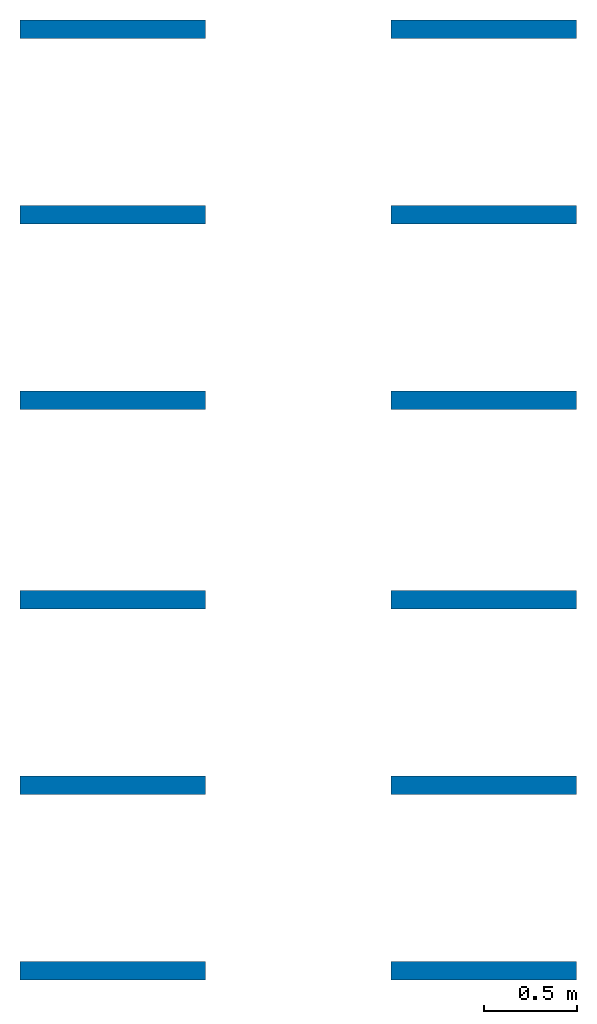
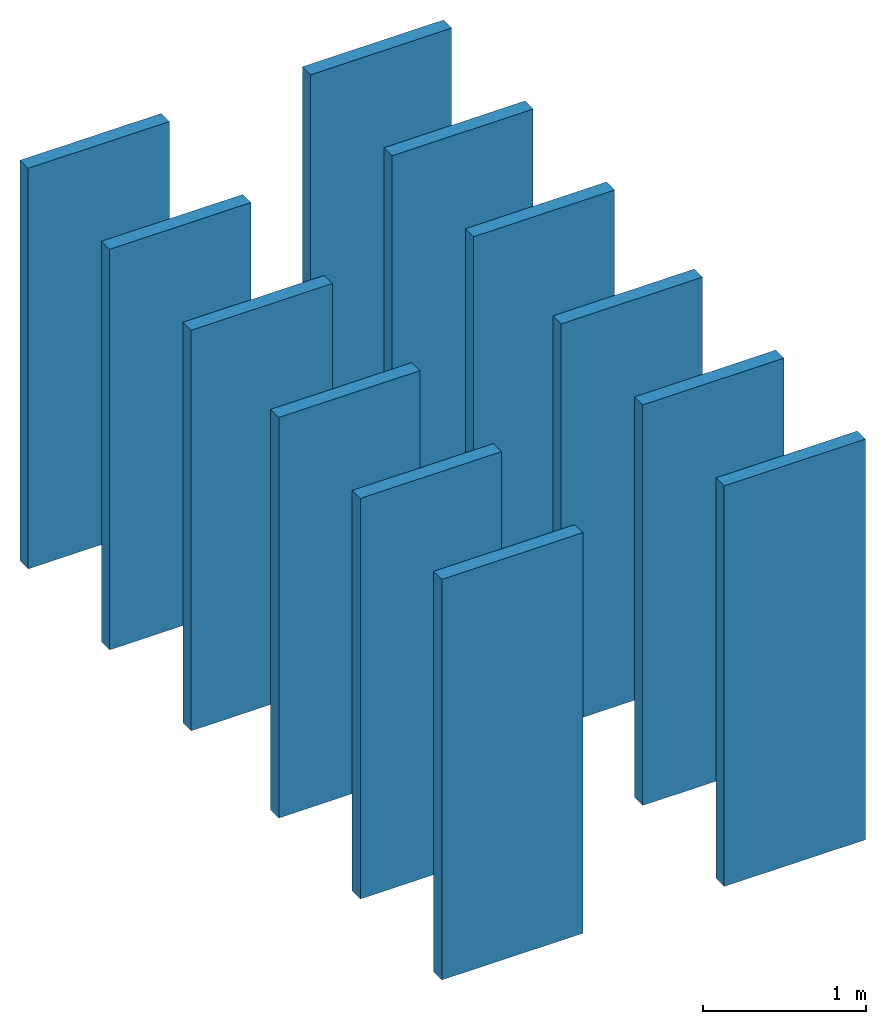
# One storey: 12 walls.
"""IFC4 building model written with IfcOpenShell, lengths in metres."""

import ifcopenshell
import ifcopenshell.guid

model = None  # the IFC model being written
_history = None  # IfcOwnerHistory: only IFC2X3 demands one
_inside = {}  # id of a spatial element -> (the spatial element, [elements in it])
_under = {}  # id of a project, library or spatial element -> (it, [spatial elements below it])
_declared = {}  # id of a project -> (the project, [libraries it declares])
_typed = {}  # id of a type object -> (the type object, [elements of that type])
_made_of = {}  # id of a material, layer set ... -> (it, [elements and type objects made of it])


def new_model(schema):
    """Start an empty IFC model of exactly this schema.

    Asked for "IFC4X3", IfcOpenShell would pick the latest addendum, in which some entities
    have other attributes; the version numbers below select the first issue.
    IFC2X3 requires an IfcOwnerHistory on every rooted entity: one is made here for all.
    """
    global model, _history
    if schema == "IFC4X3":
        model = ifcopenshell.file(schema_version=(4, 3, 0, 0))
    else:
        model = ifcopenshell.file(schema=schema)
    _inside.clear()
    _under.clear()
    _declared.clear()
    _typed.clear()
    _made_of.clear()
    _history = None
    if model.schema == "IFC2X3":
        org = make("IfcOrganization", Name="unknown")
        user = make(
            "IfcPersonAndOrganization",
            ThePerson=make("IfcPerson", FamilyName="unknown"),
            TheOrganization=org,
        )
        app = make(
            "IfcApplication",
            ApplicationDeveloper=org,
            Version="unknown",
            ApplicationFullName="unknown",
            ApplicationIdentifier="unknown",
        )
        _history = make(
            "IfcOwnerHistory",
            OwningUser=user,
            OwningApplication=app,
            ChangeAction="ADDED",
            CreationDate=0,
        )
    return model


def make(cls, **values):
    """One entity of the class cls with the attributes given. An attribute that is None is left unset."""
    return model.create_entity(
        cls, **{name: value for name, value in values.items() if value is not None}
    )


def entity(cls, *values):
    """Any entity or typed value of the class cls, its attributes in the order of the schema. None: left unset."""
    e = model.create_entity(cls)
    for i, value in enumerate(values):
        if value is not None:
            e[i] = value
    return e


def rooted(cls, **values):
    """An entity with a GlobalId (a new one), such as an element, a storey or a relation."""
    return make(cls, GlobalId=ifcopenshell.guid.new(), OwnerHistory=_history, **values)


def si_unit(unit_type, name, prefix=None):
    """IfcSIUnit, for example si_unit("LENGTHUNIT", "METRE", prefix="MILLI")."""
    return make("IfcSIUnit", UnitType=unit_type, Prefix=prefix, Name=name)


def converted_unit(unit_type, name, factor, base, dimensions=None, offset=None):
    """IfcConversionBasedUnit, such as the inch: factor (a typed value) times the base unit."""
    return make(
        "IfcConversionBasedUnit"
        if offset is None
        else "IfcConversionBasedUnitWithOffset",
        ConversionOffset=offset,
        Dimensions=None
        if dimensions is None
        else entity("IfcDimensionalExponents", *dimensions),
        UnitType=unit_type,
        Name=name,
        ConversionFactor=make(
            "IfcMeasureWithUnit", ValueComponent=factor, UnitComponent=base
        ),
    )


def assignment(units):
    """IfcUnitAssignment: the units of a project."""
    return None if units is None else make("IfcUnitAssignment", Units=units)


def point(xyz):
    """IfcCartesianPoint."""
    return None if xyz is None else make("IfcCartesianPoint", Coordinates=xyz)


def direction(xyz):
    """IfcDirection."""
    return None if xyz is None else make("IfcDirection", DirectionRatios=xyz)


def frame(location, z_axis=None, x_axis=None):
    """IfcAxis2Placement3D, a coordinate frame: its origin and axes. An axis left out is left unset."""
    return make(
        "IfcAxis2Placement3D",
        Location=point(location),
        Axis=direction(z_axis),
        RefDirection=direction(x_axis),
    )


def frame_2d(location, x_axis=None):
    """IfcAxis2Placement2D, a coordinate frame in the plane: its origin and x axis."""
    return make(
        "IfcAxis2Placement2D", Location=point(location), RefDirection=direction(x_axis)
    )


def origin_with_axes():
    """The frame at (0, 0, 0) with the z axis (0, 0, 1) and the x axis (1, 0, 0) written out."""
    return frame((0.0, 0.0, 0.0), z_axis=(0.0, 0.0, 1.0), x_axis=(1.0, 0.0, 0.0))


def origin_2d_with_axis():
    """The frame at (0, 0) in the plane with the x axis (1, 0) written out."""
    return frame_2d((0.0, 0.0), x_axis=(1.0, 0.0))


def place(relative_to, where):
    """IfcLocalPlacement: puts the frame where relative to a parent placement (None: the world)."""
    return make(
        "IfcLocalPlacement", PlacementRelTo=relative_to, RelativePlacement=where
    )


def context(
    kind, dimensions, precision=None, world=None, true_north=None, identifier=None
):
    """IfcGeometricRepresentationContext, for example the 3D "Model" context."""
    return make(
        "IfcGeometricRepresentationContext",
        ContextIdentifier=identifier,
        ContextType=kind,
        CoordinateSpaceDimension=dimensions,
        Precision=precision,
        WorldCoordinateSystem=world,
        TrueNorth=true_north,
    )


def subcontext(parent, identifier, kind, view, scale=None):
    """IfcGeometricRepresentationSubContext, for example "Body" below "Model"."""
    return make(
        "IfcGeometricRepresentationSubContext",
        ContextIdentifier=identifier,
        ContextType=kind,
        ParentContext=parent,
        TargetScale=scale,
        TargetView=view,
    )


def project(units=None, contexts=None):
    """IfcProject with its units and contexts."""
    return rooted(
        "IfcProject",
        Name="project",
        RepresentationContexts=contexts,
        UnitsInContext=assignment(units),
    )


def spatial(cls, under=None, at=None, **own):
    """A site, building, storey or space (cls), placed at a placement, below another one or the project."""
    s = rooted(cls, ObjectPlacement=at, **own)
    if under is not None:
        _under.setdefault(under.id(), (under, []))[1].append(s)
    return s


def point_list(points):
    """IfcCartesianPointList2D or 3D."""
    cls = (
        "IfcCartesianPointList2D" if len(points[0]) == 2 else "IfcCartesianPointList3D"
    )
    return make(cls, CoordList=points)


def indexed_curve(points, segments=None, self_intersect=None):
    """IfcIndexedPolyCurve: lines and arcs through numbered points (the first is 1)."""
    return make(
        "IfcIndexedPolyCurve",
        Points=point_list(points),
        Segments=segments,
        SelfIntersect=self_intersect,
    )


def outline(outer, holes=None, kind="AREA"):
    """IfcArbitraryClosedProfileDef: a profile drawn as a closed curve; with holes, ...WithVoids."""
    if holes is None:
        return make("IfcArbitraryClosedProfileDef", ProfileType=kind, OuterCurve=outer)
    return make(
        "IfcArbitraryProfileDefWithVoids",
        ProfileType=kind,
        OuterCurve=outer,
        InnerCurves=holes,
    )


def extrude(swept, where, along, depth):
    """IfcExtrudedAreaSolid: the profile swept, set in the frame where, extruded along a direction by depth."""
    return make(
        "IfcExtrudedAreaSolid",
        SweptArea=swept,
        Position=where,
        ExtrudedDirection=direction(along),
        Depth=depth,
    )


def shape(context_of_items, identifier, shape_type, items):
    """IfcShapeRepresentation: the items that make up one representation, for example the "Body"."""
    return make(
        "IfcShapeRepresentation",
        ContextOfItems=context_of_items,
        RepresentationIdentifier=identifier,
        RepresentationType=shape_type,
        Items=items,
    )


def material(Name=None, Category=None):
    """IfcMaterial."""
    return make("IfcMaterial", Name=Name, Category=Category)


def layer(
    of_material, thickness, ventilated=None, Name=None, Category=None, Priority=None
):
    """IfcMaterialLayer: one layer of a wall or slab, of a material (None: an air gap)."""
    return make(
        "IfcMaterialLayer",
        Material=of_material,
        LayerThickness=thickness,
        IsVentilated=ventilated,
        Name=Name,
        Category=Category,
        Priority=Priority,
    )


def layer_set(layers, Name=None):
    """IfcMaterialLayerSet."""
    return make("IfcMaterialLayerSet", MaterialLayers=layers, LayerSetName=Name)


def layer_usage(for_layer_set, set_direction, sense, offset, extent=None):
    """IfcMaterialLayerSetUsage: how a layer set lies in its element."""
    return make(
        "IfcMaterialLayerSetUsage",
        ForLayerSet=for_layer_set,
        LayerSetDirection=set_direction,
        DirectionSense=sense,
        OffsetFromReferenceLine=offset,
        ReferenceExtent=extent,
    )


def made_of(thing, what):
    """Note that an element or type object is made of a material, layer set ...; save() writes the relation."""
    if what is not None:
        _made_of.setdefault(what.id(), (what, []))[1].append(thing)
    return thing


def type_object(cls, material=None, **own):
    """A type object (cls), such as IfcWallType, which elements share."""
    return made_of(rooted(cls, **own), material)


def element(
    cls,
    number,
    at=None,
    inside=None,
    cuts=None,
    type_object=None,
    material=None,
    context=None,
    identifier="Body",
    shape_type=None,
    held_by="IfcProductDefinitionShape",
    body=None,
    shapes=None,
    **own,
):
    """One element of the class cls, such as IfcWall. Its Tag is "e" and its number.

    at: its placement. inside: the storey or other place that contains it. cuts: it is an
    opening in that element (IfcRelVoidsElement). A single representation is given by context,
    identifier, shape_type and body (its items); several are given by shapes. held_by: the class
    of the entity that holds the representations. save() writes the other relations.
    """
    e = rooted(cls, Tag="e%d" % number, ObjectPlacement=at, **own)
    if body is not None:
        shapes = [shape(context, identifier, shape_type, body)]
    if shapes is not None:
        e.Representation = make(held_by, Representations=shapes)
    if inside is not None:
        _inside.setdefault(inside.id(), (inside, []))[1].append(e)
    if cuts is not None:
        rooted(
            "IfcRelVoidsElement", RelatingBuildingElement=cuts, RelatedOpeningElement=e
        )
    if type_object is not None:
        _typed.setdefault(type_object.id(), (type_object, []))[1].append(e)
    return made_of(e, material)


def aggregate(whole, parts):
    """IfcRelAggregates: a whole, such as a stair, and the parts it consists of."""
    return rooted("IfcRelAggregates", RelatingObject=whole, RelatedObjects=parts)


def save(model, path):
    """Write the relations noted so far, then the file.

    IfcRelAggregates (storeys below a building ...), IfcRelContainedInSpatialStructure (elements
    in a storey), IfcRelDefinesByType, IfcRelAssociatesMaterial and IfcRelDeclares: one each for
    every whole, place, type object, material and project.
    """
    for whole, parts in _under.values():
        aggregate(whole, parts)
    for where, things in _inside.values():
        rooted(
            "IfcRelContainedInSpatialStructure",
            RelatedElements=things,
            RelatingStructure=where,
        )
    for kind, things in _typed.values():
        rooted("IfcRelDefinesByType", RelatedObjects=things, RelatingType=kind)
    for what, things in _made_of.values():
        rooted("IfcRelAssociatesMaterial", RelatedObjects=things, RelatingMaterial=what)
    for by, libraries in _declared.values():
        rooted("IfcRelDeclares", RelatingContext=by, RelatedDefinitions=libraries)
    model.write(path)


model = new_model("IFC4")

# Units and contexts
model_context = context("Model", 3, precision=1e-05, world=origin_with_axes())
plan_context = context("Plan", 2, precision=1e-05, world=origin_2d_with_axis())
body_context = subcontext(model_context, "Body", "Model", "MODEL_VIEW")
ifc_project = project(units=[si_unit("LENGTHUNIT", "METRE"), converted_unit("PLANEANGLEUNIT", "degree", entity("IfcReal", 0.0174532925199433), si_unit("PLANEANGLEUNIT", "RADIAN"), dimensions=[0, 0, 0, 0, 0, 0, 0]), si_unit("AREAUNIT", "SQUARE_METRE"), si_unit("VOLUMEUNIT", "CUBIC_METRE")], contexts=[model_context, plan_context])

# Site, building, storey
site_placement = place(None, origin_with_axes())
site = spatial("IfcSite", under=ifc_project, at=site_placement)
building_placement = place(site_placement, origin_with_axes())
building = spatial("IfcBuilding", under=site, at=building_placement, Name="Building")
storey_placement = place(building_placement, origin_with_axes())
storey = spatial("IfcBuildingStorey", under=building, at=storey_placement, Name="Storey")

# Walls
ifc_material = material()
ifc_layer_1 = layer(ifc_material, 0.1)
ifc_layer_set_1 = layer_set([ifc_layer_1], Name="concrete")
ifc_layer_usage_1 = layer_usage(ifc_layer_set_1, "AXIS2", "POSITIVE", 0.0)
wall_type_1 = type_object("IfcWallType", Name="WAL100_CONCRETE", PredefinedType="NOTDEFINED", material=ifc_layer_set_1)
wall_1_placement = place(storey_placement, origin_with_axes())
element("IfcWall", 1, at=wall_1_placement, inside=storey, type_object=wall_type_1, material=ifc_layer_usage_1, Name="Wall", context=body_context, shape_type="SweptSolid", body=[
    extrude(outline(indexed_curve([(0.0, 0.0), (0.0, 0.1), (1.0, 0.1), (1.0, 0.0), (0.0, 0.0)], self_intersect=False)), origin_with_axes(), (0.0, 0.0, 1.0), 3.0),
])
ifc_layer_usage_2 = layer_usage(ifc_layer_set_1, "AXIS2", "POSITIVE", 0.0)
wall_2_placement = place(storey_placement, frame((0.0, -1.07596433162689, 0.0), z_axis=(0.0, 0.0, 1.0), x_axis=(1.0, 0.0, 0.0)))
element("IfcWall", 2, at=wall_2_placement, inside=storey, type_object=wall_type_1, material=ifc_layer_usage_2, Name="Wall", context=body_context, shape_type="SweptSolid", body=[
    extrude(outline(indexed_curve([(0.0, 0.0), (0.0, 0.1), (1.0, 0.1), (1.0, 0.0), (0.0, 0.0)], self_intersect=False)), origin_with_axes(), (0.0, 0.0, 1.0), 3.0),
])
ifc_layer_usage_3 = layer_usage(ifc_layer_set_1, "AXIS2", "POSITIVE", 0.0)
wall_3_placement = place(storey_placement, frame((0.0, -3.07596445083618, 0.0), z_axis=(0.0, 0.0, 1.0), x_axis=(1.0, 0.0, 0.0)))
element("IfcWall", 3, at=wall_3_placement, inside=storey, type_object=wall_type_1, material=ifc_layer_usage_3, Name="Wall", context=body_context, shape_type="SweptSolid", body=[
    extrude(outline(indexed_curve([(0.0, 0.0), (0.0, 0.1), (1.0, 0.1), (1.0, 0.0), (0.0, 0.0)], self_intersect=False)), origin_with_axes(), (0.0, 0.0, 1.0), 3.0),
])
ifc_layer_usage_4 = layer_usage(ifc_layer_set_1, "AXIS2", "POSITIVE", 0.0)
wall_4_placement = place(storey_placement, frame((0.0, -2.07596445083618, 0.0), z_axis=(0.0, 0.0, 1.0), x_axis=(1.0, 0.0, 0.0)))
element("IfcWall", 4, at=wall_4_placement, inside=storey, type_object=wall_type_1, material=ifc_layer_usage_4, Name="Wall", context=body_context, shape_type="SweptSolid", body=[
    extrude(outline(indexed_curve([(0.0, 0.0), (0.0, 0.1), (1.0, 0.1), (1.0, 0.0), (0.0, 0.0)], self_intersect=False)), origin_with_axes(), (0.0, 0.0, 1.0), 3.0),
])
ifc_layer_2 = layer(ifc_material, 0.1)
ifc_layer_set_2 = layer_set([ifc_layer_2], Name="brick")
ifc_layer_usage_5 = layer_usage(ifc_layer_set_2, "AXIS2", "POSITIVE", 0.0)
wall_type_2 = type_object("IfcWallType", Name="WAL100_BRICK", PredefinedType="NOTDEFINED", material=ifc_layer_set_2)
wall_5_placement = place(storey_placement, frame((2.0, 0.0, 0.0), z_axis=(0.0, 0.0, 1.0), x_axis=(1.0, 0.0, 0.0)))
element("IfcWall", 5, at=wall_5_placement, inside=storey, type_object=wall_type_2, material=ifc_layer_usage_5, Name="Wall", context=body_context, shape_type="SweptSolid", body=[
    extrude(outline(indexed_curve([(0.0, 0.0), (0.0, 0.1), (1.0, 0.1), (1.0, 0.0), (0.0, 0.0)], self_intersect=False)), origin_with_axes(), (0.0, 0.0, 1.0), 3.0),
])
ifc_layer_usage_6 = layer_usage(ifc_layer_set_2, "AXIS2", "POSITIVE", 0.0)
wall_6_placement = place(storey_placement, frame((2.0, -2.07596445083618, 0.0), z_axis=(0.0, 0.0, 1.0), x_axis=(1.0, 0.0, 0.0)))
element("IfcWall", 6, at=wall_6_placement, inside=storey, type_object=wall_type_2, material=ifc_layer_usage_6, Name="Wall", context=body_context, shape_type="SweptSolid", body=[
    extrude(outline(indexed_curve([(0.0, 0.0), (0.0, 0.1), (1.0, 0.1), (1.0, 0.0), (0.0, 0.0)], self_intersect=False)), origin_with_axes(), (0.0, 0.0, 1.0), 3.0),
])
ifc_layer_usage_7 = layer_usage(ifc_layer_set_2, "AXIS2", "POSITIVE", 0.0)
wall_7_placement = place(storey_placement, frame((2.0, -3.07596445083618, 0.0), z_axis=(0.0, 0.0, 1.0), x_axis=(1.0, 0.0, 0.0)))
element("IfcWall", 7, at=wall_7_placement, inside=storey, type_object=wall_type_2, material=ifc_layer_usage_7, Name="Wall", context=body_context, shape_type="SweptSolid", body=[
    extrude(outline(indexed_curve([(0.0, 0.0), (0.0, 0.1), (1.0, 0.1), (1.0, 0.0), (0.0, 0.0)], self_intersect=False)), origin_with_axes(), (0.0, 0.0, 1.0), 3.0),
])
ifc_layer_usage_8 = layer_usage(ifc_layer_set_2, "AXIS2", "POSITIVE", 0.0)
wall_8_placement = place(storey_placement, frame((2.0, -1.07596433162689, 0.0), z_axis=(0.0, 0.0, 1.0), x_axis=(1.0, 0.0, 0.0)))
element("IfcWall", 8, at=wall_8_placement, inside=storey, type_object=wall_type_2, material=ifc_layer_usage_8, Name="Wall", context=body_context, shape_type="SweptSolid", body=[
    extrude(outline(indexed_curve([(0.0, 0.0), (0.0, 0.1), (1.0, 0.1), (1.0, 0.0), (0.0, 0.0)], self_intersect=False)), origin_with_axes(), (0.0, 0.0, 1.0), 3.0),
])
ifc_layer_3 = layer(ifc_material, 0.1)
ifc_layer_set_3 = layer_set([ifc_layer_3])
ifc_layer_usage_9 = layer_usage(ifc_layer_set_3, "AXIS2", "POSITIVE", 0.0)
wall_type_3 = type_object("IfcWallType", Name="WAL100_CONC DEMO", PredefinedType="NOTDEFINED", material=ifc_layer_set_3)
wall_9_placement = place(storey_placement, frame((0.0, 2.0, 0.0), z_axis=(0.0, 0.0, 1.0), x_axis=(1.0, 0.0, 0.0)))
element("IfcWall", 9, at=wall_9_placement, inside=storey, type_object=wall_type_3, material=ifc_layer_usage_9, Name="Wall", context=body_context, shape_type="SweptSolid", body=[
    extrude(outline(indexed_curve([(0.0, 0.0), (0.0, 0.1), (1.0, 0.1), (1.0, 0.0), (0.0, 0.0)], self_intersect=False)), origin_with_axes(), (0.0, 0.0, 1.0), 3.0),
])
ifc_layer_4 = layer(ifc_material, 0.1)
ifc_layer_set_4 = layer_set([ifc_layer_4])
ifc_layer_usage_10 = layer_usage(ifc_layer_set_4, "AXIS2", "POSITIVE", 0.0)
wall_type_4 = type_object("IfcWallType", Name="WAL100_CONC. NEW", PredefinedType="NOTDEFINED", material=ifc_layer_set_4)
wall_10_placement = place(storey_placement, frame((0.0, 1.0, 0.0), z_axis=(0.0, 0.0, 1.0), x_axis=(1.0, 0.0, 0.0)))
element("IfcWall", 10, at=wall_10_placement, inside=storey, type_object=wall_type_4, material=ifc_layer_usage_10, Name="Wall", context=body_context, shape_type="SweptSolid", body=[
    extrude(outline(indexed_curve([(0.0, 0.0), (0.0, 0.1), (1.0, 0.1), (1.0, 0.0), (0.0, 0.0)], self_intersect=False)), origin_with_axes(), (0.0, 0.0, 1.0), 3.0),
])
ifc_layer_5 = layer(ifc_material, 0.1)
ifc_layer_set_5 = layer_set([ifc_layer_5])
ifc_layer_usage_11 = layer_usage(ifc_layer_set_5, "AXIS2", "POSITIVE", 0.0)
wall_type_5 = type_object("IfcWallType", Name="WAL100_BRICK NEW", PredefinedType="NOTDEFINED", material=ifc_layer_set_5)
wall_11_placement = place(storey_placement, frame((2.0, 1.0, 0.0), z_axis=(0.0, 0.0, 1.0), x_axis=(1.0, 0.0, 0.0)))
element("IfcWall", 11, at=wall_11_placement, inside=storey, type_object=wall_type_5, material=ifc_layer_usage_11, Name="Wall", context=body_context, shape_type="SweptSolid", body=[
    extrude(outline(indexed_curve([(0.0, 0.0), (0.0, 0.1), (1.0, 0.1), (1.0, 0.0), (0.0, 0.0)], self_intersect=False)), origin_with_axes(), (0.0, 0.0, 1.0), 3.0),
])
ifc_layer_6 = layer(ifc_material, 0.1)
ifc_layer_set_6 = layer_set([ifc_layer_6])
ifc_layer_usage_12 = layer_usage(ifc_layer_set_6, "AXIS2", "POSITIVE", 0.0)
wall_type_6 = type_object("IfcWallType", Name="WAL100_BRICK DEMO", PredefinedType="NOTDEFINED", material=ifc_layer_set_6)
wall_12_placement = place(storey_placement, frame((2.0, 2.0, 0.0), z_axis=(0.0, 0.0, 1.0), x_axis=(1.0, 0.0, 0.0)))
element("IfcWall", 12, at=wall_12_placement, inside=storey, type_object=wall_type_6, material=ifc_layer_usage_12, Name="Wall", context=body_context, shape_type="SweptSolid", body=[
    extrude(outline(indexed_curve([(0.0, 0.0), (0.0, 0.1), (1.0, 0.1), (1.0, 0.0), (0.0, 0.0)], self_intersect=False)), origin_with_axes(), (0.0, 0.0, 1.0), 3.0),
])

save(model, "model.ifc")
